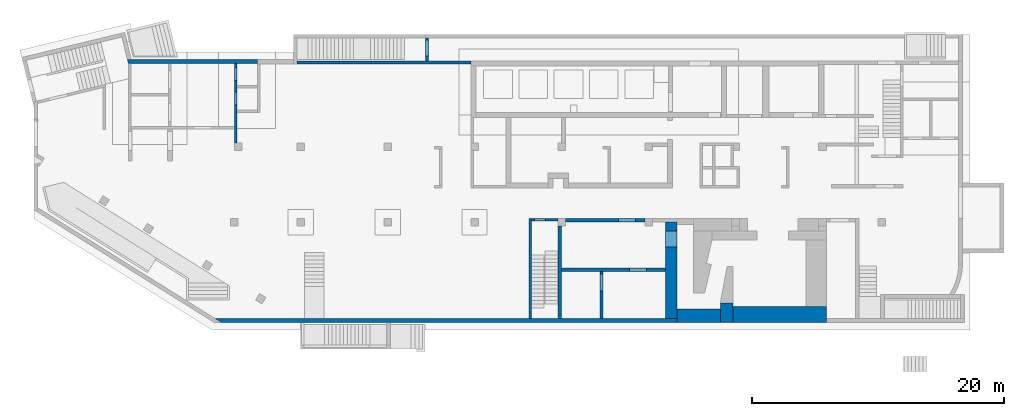
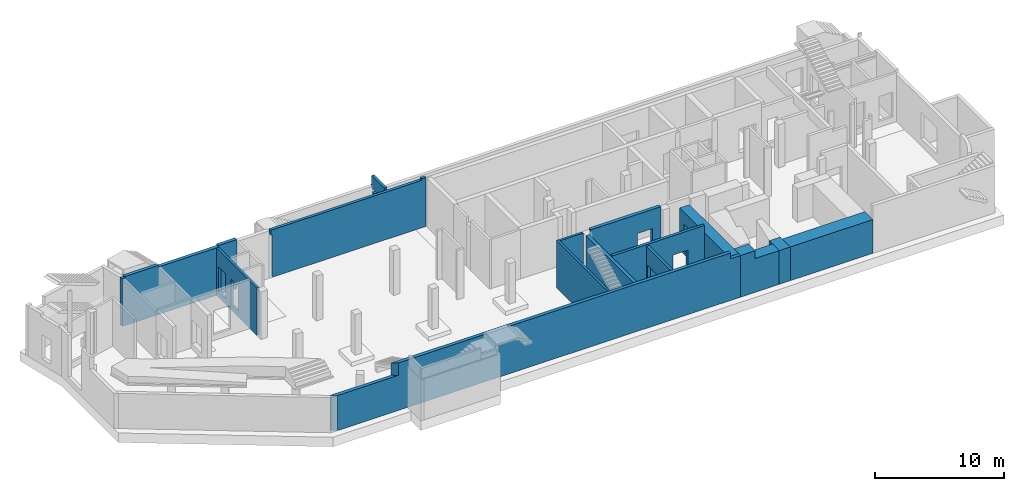
# One storey, part 6 of 9: 15 walls, 9 openings.
"""IFC4 building model written with IfcOpenShell, lengths in millimetres."""

from ifc_helpers import new_model, entity, si_unit, converted_unit, derived_unit, direction, frame, origin, place, context, subcontext, project, spatial, indexed_curve, outline, extrude, polygons, material, type_object, element, save


model = new_model("IFC4")

# Units and contexts
model_context = context("Model", 3, precision=0.01, world=origin(), true_north=direction((6.12303176911189e-17, 1.0)))
plan_context = context("Plan", 3, precision=0.01, world=origin(), true_north=direction((6.12303176911189e-17, 1.0)))
body_context = subcontext(model_context, "Body", "Model", "MODEL_VIEW")
ifc_project = project(units=[si_unit("LENGTHUNIT", "METRE", prefix="MILLI"), si_unit("AREAUNIT", "SQUARE_METRE"), si_unit("VOLUMEUNIT", "CUBIC_METRE"), converted_unit("PLANEANGLEUNIT", "DEGREE", entity("IfcRatioMeasure", 0.0174532925199433), si_unit("PLANEANGLEUNIT", "RADIAN"), dimensions=[0, 0, 0, 0, 0, 0, 0]), si_unit("MASSUNIT", "GRAM", prefix="KILO"), derived_unit("MASSDENSITYUNIT", [(si_unit("MASSUNIT", "GRAM", prefix="KILO"), 1), (si_unit("LENGTHUNIT", "METRE"), -3)]), derived_unit("MOMENTOFINERTIAUNIT", [(si_unit("LENGTHUNIT", "METRE"), 4)]), si_unit("TIMEUNIT", "SECOND"), si_unit("FREQUENCYUNIT", "HERTZ"), si_unit("THERMODYNAMICTEMPERATUREUNIT", "DEGREE_CELSIUS"), derived_unit("THERMALTRANSMITTANCEUNIT", [(si_unit("MASSUNIT", "GRAM", prefix="KILO"), 1), (si_unit("THERMODYNAMICTEMPERATUREUNIT", "KELVIN"), -1), (si_unit("TIMEUNIT", "SECOND"), -3)]), derived_unit("VOLUMETRICFLOWRATEUNIT", [(si_unit("LENGTHUNIT", "METRE"), 3), (si_unit("TIMEUNIT", "SECOND"), -1)]), derived_unit("MASSFLOWRATEUNIT", [(si_unit("MASSUNIT", "GRAM", prefix="KILO"), 1), (si_unit("TIMEUNIT", "SECOND"), -1)]), derived_unit("ROTATIONALFREQUENCYUNIT", [(si_unit("TIMEUNIT", "SECOND"), -1)]), si_unit("ELECTRICCURRENTUNIT", "AMPERE"), si_unit("ELECTRICVOLTAGEUNIT", "VOLT"), si_unit("POWERUNIT", "WATT"), si_unit("FORCEUNIT", "NEWTON", prefix="KILO"), si_unit("ILLUMINANCEUNIT", "LUX"), si_unit("LUMINOUSFLUXUNIT", "LUMEN"), si_unit("LUMINOUSINTENSITYUNIT", "CANDELA"), derived_unit("USERDEFINED", [(si_unit("MASSUNIT", "GRAM", prefix="KILO"), -1), (si_unit("LENGTHUNIT", "METRE"), -2), (si_unit("TIMEUNIT", "SECOND"), 3), (si_unit("LUMINOUSFLUXUNIT", "LUMEN"), 1)]), derived_unit("LINEARVELOCITYUNIT", [(si_unit("LENGTHUNIT", "METRE"), 1), (si_unit("TIMEUNIT", "SECOND"), -1)]), si_unit("PRESSUREUNIT", "PASCAL"), derived_unit("USERDEFINED", [(si_unit("LENGTHUNIT", "METRE"), -2), (si_unit("MASSUNIT", "GRAM", prefix="KILO"), 1), (si_unit("TIMEUNIT", "SECOND"), -2)]), derived_unit("LINEARFORCEUNIT", [(si_unit("MASSUNIT", "GRAM", prefix="KILO"), 1), (si_unit("LENGTHUNIT", "METRE"), 1), (si_unit("TIMEUNIT", "SECOND"), -2), (si_unit("LENGTHUNIT", "METRE"), -1)]), derived_unit("PLANARFORCEUNIT", [(si_unit("MASSUNIT", "GRAM", prefix="KILO"), 1), (si_unit("LENGTHUNIT", "METRE"), 1), (si_unit("TIMEUNIT", "SECOND"), -2), (si_unit("LENGTHUNIT", "METRE"), -2)])], contexts=[model_context, plan_context])

# Site, building, storey
site_placement = place(None, origin())
site = spatial("IfcSite", under=ifc_project, at=site_placement, CompositionType="ELEMENT")
building_placement = place(site_placement, origin())
building = spatial("IfcBuilding", under=site, at=building_placement, CompositionType="ELEMENT")
storey_placement = place(building_placement, frame((0.0, 0.0, -4900.0)))
storey = spatial("IfcBuildingStorey", under=building, at=storey_placement, CompositionType="ELEMENT", Elevation=-4900.0)

# Wall
ifc_material = material()
wall_type_1 = type_object("IfcWallType", Name=":ADSK_ 25_200", PredefinedType="STANDARD")
wall_1_placement = place(storey_placement, frame((39370.0, 50.0, 0.0), z_axis=(0.0, 0.0, 1.0), x_axis=(0.0, 1.0, 0.0)))
element("IfcWall", 1, at=wall_1_placement, inside=storey, type_object=wall_type_1, material=ifc_material, Name=":ADSK_ 25_200", ObjectType=":ADSK_ 25_200", PredefinedType="NOTDEFINED", context=body_context, shape_type="Tessellation", body=[
    polygons([(3.8915537459161e-13, -99.9999999999945, 0.0), (7749.99999999991, -99.9999999999934, 0.0), (7949.99999999991, -99.9999999999932, 0.0), (7949.99999999991, -99.9999999999932, 4500.0), (7749.99999999991, -99.9999999999934, 4500.0), (5325.0, -99.9999999999965, 4500.0), (1.26898491714655e-13, -99.9999999999945, 4500.0), (1.91193727516747e-12, 100.000000000003, 0.0), (1.51432200112822e-12, 100.000000000003, 4500.0), (7949.99999999991, 100.000000000005, 4500.0), (7949.99999999991, 100.000000000005, 0.0)], [[[1, 2, 3, 4, 5, 6, 7]], [[8, 9, 10, 11]], [[3, 2, 1, 8, 11]], [[1, 7, 9, 8]], [[4, 3, 11, 10]], [[7, 6, 5, 4, 10, 9]]], closed=True),
])

# Wall, opening
wall_2_placement = place(storey_placement, frame((41570.0, 7900.0, 0.0), z_axis=(0.0, 0.0, 1.0), x_axis=(-1.0, 0.0, 0.0)))
wall_2 = element("IfcWall", 2, at=wall_2_placement, inside=storey, type_object=wall_type_1, material=ifc_material, Name=":ADSK_ 25_200", ObjectType=":ADSK_ 25_200", PredefinedType="NOTDEFINED", context=body_context, shape_type="Tessellation", body=[
    polygons([(1.18902794510068e-12, -100.0, 0.0), (2100.00000000002, -100.000000000001, 0.0), (2100.00000000002, -100.000000000001, 4500.0), (1.18902794510068e-12, -100.0, 4500.0), (960.000000000008, -100.0, 2829.99999999805), (1840.00000000001, -100.000000000001, 2829.99999999804), (1840.00000000001, -100.000000000001, 550.0), (960.000000000008, -100.0, 550.0), (2100.00000000002, 99.9999999999978, 0.0), (5.09581903187964e-13, 100.0, 0.0), (5.09581903187964e-13, 100.0, 4500.0), (2100.00000000002, 99.9999999999978, 4500.0), (1840.00000000001, 99.9999999999989, 2829.99999999804), (960.000000000008, 100.000000000001, 2829.99999999805), (960.000000000008, 100.000000000001, 550.0), (1840.00000000001, 99.9999999999989, 550.0)], [[[1, 2, 3, 4], [5, 6, 7, 8]], [[9, 10, 11, 12], [13, 14, 15, 16]], [[2, 1, 10, 9]], [[4, 3, 12, 11]], [[1, 4, 11, 10]], [[3, 2, 9, 12]], [[5, 14, 13, 6]], [[6, 13, 16, 7]], [[7, 16, 15, 8]], [[14, 5, 8, 15]]], closed=True),
])
opening_1_placement = place(wall_2_placement, frame((41570.0, 7900.0, 0.0), z_axis=(0.0, 0.0, 1.0), x_axis=(-1.0, 0.0, 0.0)))
element("IfcOpeningElement", 3, at=opening_1_placement, cuts=wall_2, Name=":ADSK_ 25_200", PredefinedType="OPENING", context=body_context, shape_type="SweptSolid", body=[
    extrude(outline(indexed_curve([(-439.999999999995, -1139.99999999902), (440.000000000004, -1139.99999999902), (440.000000000004, 1139.99999999902), (-439.999999999995, 1139.99999999902), (-439.999999999995, -1139.99999999902)], self_intersect=False)), frame((40170.0, 8100.0, 1690.0), z_axis=(0.0, -1.0, 0.0), x_axis=(-1.0, 0.0, 0.0)), (0.0, 0.0, 1.0), 400.000000001942),
])

# Wall, openings
wall_3_placement = place(storey_placement, frame((16000.0, 14000.0, 0.0), z_axis=(0.0, 0.0, 1.0), x_axis=(0.0, 1.0, 0.0)))
wall_3 = element("IfcWall", 4, at=wall_3_placement, inside=storey, type_object=wall_type_1, material=ifc_material, Name=":ADSK_ 25_200", ObjectType=":ADSK_ 25_200", PredefinedType="NOTDEFINED", context=body_context, shape_type="Tessellation", body=[
    polygons([(0.0, -100.000000000001, 0.0), (2399.99999999961, -100.000000000001, 0.0), (2599.99999999961, -100.000000000001, 0.0), (4349.9999999998, -99.9999999999999, 0.0), (4549.9999999998, -100.000000000002, 0.0), (6300.0, -99.9999999999987, 0.0), (6300.0, -99.9999999999987, 4500.0), (2500.00063936648, -100.000000000001, 4500.0), (0.0, -100.000000000001, 4500.0), (2980.0, -100.0, 2919.99999999804), (4020.0, -100.0, 2919.99999999804), (4020.0, -100.0, 550.0), (2980.0, -100.0, 550.0), (4930.00000000001, -100.000000000001, 2919.99999999804), (5970.0, -99.9999999999992, 2919.99999999804), (5970.0, -99.9999999999992, 550.0), (4930.00000000001, -100.000000000001, 550.0), (6300.0, 99.9999999999992, 0.0), (1299.99999999955, 99.9999999999992, 0.0), (1099.99999999955, 99.9999999999989, 0.0), (0.0, 99.9999999999992, 0.0), (0.0, 99.9999999999992, 4500.0), (6300.0, 99.9999999999992, 4500.0), (4020.0, 99.9999999999996, 2919.99999999804), (2980.0, 99.9999999999978, 2919.99999999804), (2980.00000000001, 99.9999999999978, 550.0), (4020.0, 99.9999999999996, 550.0), (5970.0, 99.9999999999986, 2919.99999999804), (4930.00000000001, 99.999999999999, 2919.99999999804), (4930.00000000001, 99.999999999999, 550.0), (5970.0, 99.9999999999986, 550.0)], [[[1, 2, 3, 4, 5, 6, 7, 8, 9], [10, 11, 12, 13], [14, 15, 16, 17]], [[18, 19, 20, 21, 22, 23], [24, 25, 26, 27], [28, 29, 30, 31]], [[6, 5, 4, 3, 2, 1, 21, 20, 19, 18]], [[9, 8, 7, 23, 22]], [[1, 9, 22, 21]], [[7, 6, 18, 23]], [[24, 11, 10, 25]], [[25, 10, 13, 26]], [[26, 13, 12, 27]], [[11, 24, 27, 12]], [[28, 15, 14, 29]], [[29, 14, 17, 30]], [[30, 17, 16, 31]], [[15, 28, 31, 16]]], closed=True),
])
placement_1 = place(wall_3_placement, frame((-14000.0, 16000.0, 0.0), z_axis=(0.0, 0.0, 1.0), x_axis=(0.0, -1.0, 0.0)))
element("IfcOpeningElement", 5, at=placement_1, cuts=wall_3, Name=":ADSK_ 25_200", PredefinedType="OPENING", context=body_context, shape_type="SweptSolid", body=[
    extrude(outline(indexed_curve([(-1184.99999999902, -519.999999999999), (1184.99999999902, -519.999999999999), (1184.99999999902, 520.000000000001), (-1184.99999999902, 520.000000000001), (-1184.99999999902, -519.999999999999)], self_intersect=False)), frame((16200.0, 17500.0, 1735.0), z_axis=(-1.0, 0.0, 0.0), x_axis=(0.0, 0.0, -1.0)), (0.0, 0.0, 1.0), 400.000000001943),
])
element("IfcOpeningElement", 6, at=placement_1, cuts=wall_3, Name=":ADSK_ 25_200", PredefinedType="OPENING", context=body_context, shape_type="SweptSolid", body=[
    extrude(outline(indexed_curve([(-1184.99999999902, -519.999999999999), (1184.99999999902, -519.999999999999), (1184.99999999902, 519.999999999999), (-1184.99999999902, 519.999999999999), (-1184.99999999902, -519.999999999999)], self_intersect=False)), frame((16200.0, 19450.0, 1735.0), z_axis=(-1.0, 0.0, 0.0), x_axis=(0.0, 0.0, -1.0)), (0.0, 0.0, 1.0), 400.000000001943),
])

# Walls
wall_type_2 = type_object("IfcWallType", Name=":ADSK_ 25_300", PredefinedType="STANDARD")
wall_4_placement = place(storey_placement, frame((7420.41, 20450.0, 0.0)))
element("IfcWall", 7, at=wall_4_placement, inside=storey, type_object=wall_type_2, material=ifc_material, Name=":ADSK_ 25_300", ObjectType=":ADSK_ 25_300", PredefinedType="NOTDEFINED", context=body_context, shape_type="Tessellation", body=[
    polygons([(73.128173937497, -150.000000000005, 0.0), (79.587699244774, -150.000000000005, 0.0), (279.587699244774, -150.000000000005, 0.0), (3279.58769924477, -150.000000000005, 0.0), (3479.58769924477, -150.000000000001, 0.0), (8479.58769924478, -150.000000000001, 0.0), (8679.58769924478, -150.000000000001, 0.0), (10304.5876992448, -150.000000000005, 0.0), (10304.5876992448, -150.000000000005, 4500.0), (10304.5876992448, -150.000000000005, 4650.0), (8679.58769924479, -150.000000000001, 4650.0), (8679.58769924479, -150.000000000001, 4500.0), (8479.58769924478, -150.000000000001, 4500.0), (3479.58769924477, -150.000000000001, 4500.0), (3279.58769924479, -150.000000000005, 4500.0), (3279.58769924479, -150.000000000005, 4650.0), (279.587699244795, -150.000000000005, 4650.0), (279.587699244795, -150.000000000005, 4500.0), (79.587699244774, -150.000000000005, 4500.0), (73.1281739374959, -150.000000000005, 4500.0), (10304.5876992448, 149.999999999996, 0.0), (308.784277163578, 149.999999999996, 0.0), (2.77954970644349e-12, 150.000000000001, 0.0), (6.13815447846702e-13, 150.000000000001, 1670.0), (6.13815447846702e-13, 150.000000000001, 1870.0), (-4.69051681451691e-13, 150.000000000001, 4500.0), (279.587699244792, 149.999999999996, 4500.0), (279.587699244792, 149.999999999996, 4650.0), (3279.58769924479, 149.999999999996, 4650.0), (3279.58769924479, 149.999999999992, 4500.0), (8679.58769924478, 150.000000000001, 4500.0), (8679.58769924478, 150.000000000001, 4650.0), (10304.5876992448, 149.999999999996, 4650.0), (10304.5876992448, 149.999999999996, 4500.0), (10304.5876992448, 50.0006393664798, 4650.0)], [[[1, 2, 3, 4, 5, 6, 7, 8, 9, 10, 11, 12, 13, 14, 15, 16, 17, 18, 19, 20]], [[21, 22, 23, 24, 25, 26, 27, 28, 29, 30, 31, 32, 33, 34]], [[8, 7, 6, 5, 4, 3, 2, 1, 23, 22, 21]], [[11, 10, 35, 33, 32]], [[23, 1, 20, 26, 25, 24]], [[8, 21, 34, 33, 35, 10, 9]], [[12, 31, 30, 15, 14, 13]], [[27, 18, 17, 28]], [[15, 30, 29, 16]], [[31, 12, 11, 32]], [[18, 27, 26, 20, 19]], [[17, 16, 29, 28]]], closed=True),
])
wall_5_placement = place(storey_placement, frame((14391.94, -100.0, 0.0)))
element("IfcWall", 8, at=wall_5_placement, inside=storey, type_object=wall_type_2, material=ifc_material, Name=":ADSK_ 25_300", ObjectType=":ADSK_ 25_300", PredefinedType="NOTDEFINED", context=body_context, shape_type="Tessellation", body=[
    polygons([(480.109728548428, -150.0, 0.0), (6748.06078403981, -150.0, 0.0), (7048.06078403981, -150.0, 0.0), (13598.0607840398, -150.0, 0.0), (13898.0607840398, -150.0, 0.0), (36628.0607840398, -150.0, 0.0), (36628.0607840398, -150.000000000014, 3950.0), (35728.0607840398, -150.0, 3950.0), (35728.0607840398, -150.0, 4500.0), (27178.0607840398, -150.0, 4500.0), (25078.0607840398, -150.000000000001, 4500.0), (5952.71829370465, -150.000000000001, 4500.0), (5952.71829370465, -150.000000000002, 3580.0), (5952.71829370465, -150.000000000001, 3330.0), (480.109728548424, -150.0, 3330.0), (-2.51150603102073e-12, 150.0, 0.0), (6.15143100336641e-12, 150.000000000001, 3330.0), (5472.60856515624, 149.999999999999, 3330.0), (5472.60856515624, 149.999999999999, 4500.0), (6793.58304640091, 150.0, 4500.0), (24878.0607840398, 150.0, 4500.0), (25078.0607840398, 150.0, 4500.0), (27178.0607840398, 150.0, 4500.0), (27478.0607840398, 150.0, 4500.0), (30508.0607840398, 150.0, 4500.0), (30758.0607840398, 150.0, 4500.0), (35728.0607840398, 150.0, 4500.0), (35728.0607840398, 150.0, 3950.0), (36628.0607840398, 150.0, 3950.0), (36628.0607840398, 150.0, 0.0), (35728.0607840398, 150.0, 0.0), (30758.0607840398, 150.0, 0.0), (30508.0607840398, 150.0, 0.0), (27478.0607840398, 150.0, 0.0), (27178.0607840398, 150.0, 0.0), (25078.0607840398, 150.0, 0.0), (24878.0607840398, 150.0, 0.0)], [[[1, 2, 3, 4, 5, 6, 7, 8, 9, 10, 11, 12, 13, 14, 15]], [[16, 17, 18, 19, 20, 21, 22, 23, 24, 25, 26, 27, 28, 29, 30, 31, 32, 33, 34, 35, 36, 37]], [[6, 5, 4, 3, 2, 1, 16, 37, 36, 35, 34, 33, 32, 31, 30]], [[1, 15, 17, 16]], [[7, 6, 30, 29]], [[11, 10, 23, 22]], [[12, 19, 18, 14, 13]], [[27, 9, 8, 28]], [[10, 9, 27, 26, 25, 24, 23]], [[12, 11, 22, 21, 20, 19]], [[15, 14, 18, 17]], [[8, 7, 29, 28]]], closed=True),
])
wall_6_placement = place(storey_placement, frame((41720.0, 50.0, 0.0), z_axis=(0.0, 0.0, 1.0), x_axis=(0.0, 1.0, 0.0)))
element("IfcWall", 9, at=wall_6_placement, inside=storey, type_object=wall_type_2, material=ifc_material, Name=":ADSK_ 25_300", ObjectType=":ADSK_ 25_300", PredefinedType="NOTDEFINED", context=body_context, shape_type="Tessellation", body=[
    polygons([(3.38395977905748e-14, -150.000000000001, 0.0), (3749.99999999999, -150.000000000005, 0.0), (3999.99999999999, -150.000000000004, 0.0), (7349.99999999992, -150.000000000001, 0.0), (7349.99999999992, -150.000000000001, 4500.0), (8.45989944764369e-15, -150.000000000001, 4500.0), (1.81887838124339e-12, 150.000000000001, 0.0), (1.75965908510989e-12, 150.000000000001, 4500.0), (5325.00000000001, 149.999999999998, 4500.0), (7349.99999999992, 150.000000000001, 4500.0), (7349.99999999992, 150.000000000001, 0.0)], [[[1, 2, 3, 4, 5, 6]], [[7, 8, 9, 10, 11]], [[4, 3, 2, 1, 7, 11]], [[5, 4, 11, 10]], [[1, 6, 8, 7]], [[6, 5, 10, 9, 8]]], closed=True),
])

# Wall, opening
wall_7_placement = place(storey_placement, frame((42170.0, 7850.0, 0.0)))
wall_7 = element("IfcWall", 10, at=wall_7_placement, inside=storey, type_object=wall_type_2, material=ifc_material, Name=":ADSK_ 25_300", ObjectType=":ADSK_ 25_300", PredefinedType="NOTDEFINED", context=body_context, shape_type="Tessellation", body=[
    polygons([(8.42232516012628e-13, -149.999999999999, 0.0), (6299.99999999999, -149.999999999999, 0.0), (6299.99999999999, -149.999999999999, 4650.0), (8.42232516012628e-13, -149.999999999999, 4650.0), (4199.99999999998, -149.999999999998, 2829.99999999805), (5549.99999999999, -149.999999999998, 2829.99999999804), (5549.99999999999, -149.999999999998, 550.0), (4199.99999999998, -149.999999999998, 550.0), (6299.99999999999, 150.000000000001, 0.0), (-1.37504410495438e-13, 149.999999999999, 0.0), (-1.37504410495442e-13, 150.000000000001, 4500.0), (-1.37504410495438e-13, 149.999999999999, 4650.0), (6299.99999999999, 150.000000000001, 4650.0), (6299.99999999999, 150.000000000001, 4500.0), (5549.99999999999, 150.000000000001, 2829.99999999804), (4199.99999999998, 150.000000000001, 2829.99999999805), (4199.99999999998, 150.000000000001, 550.0), (5549.99999999999, 150.000000000001, 550.0)], [[[1, 2, 3, 4], [5, 6, 7, 8]], [[9, 10, 11, 12, 13, 14], [15, 16, 17, 18]], [[2, 1, 10, 9]], [[3, 2, 9, 14, 13]], [[4, 3, 13, 12]], [[1, 4, 12, 11, 10]], [[5, 16, 15, 6]], [[6, 15, 18, 7]], [[7, 18, 17, 8]], [[16, 5, 8, 17]]], closed=True),
])
opening_4_placement = place(wall_7_placement, frame((-42170.0, -7850.0, 0.0)))
element("IfcOpeningElement", 11, at=opening_4_placement, cuts=wall_7, Name=":ADSK_ 25_300", PredefinedType="OPENING", context=body_context, shape_type="SweptSolid", body=[
    extrude(outline(indexed_curve([(-675.000000000003, -1139.99999999902), (674.999999999994, -1139.99999999902), (674.999999999994, 1139.99999999902), (-675.000000000003, 1139.99999999902), (-675.000000000003, -1139.99999999902)], self_intersect=False)), frame((47045.0, 7600.0, 1690.0), z_axis=(0.0, 1.0, 0.0), x_axis=(1.0, 0.0, 0.0)), (0.0, 0.0, 1.0), 500.000000001943),
])

wall_type_3 = type_object("IfcWallType", Name=":ADSK_ 25_250", PredefinedType="STANDARD")
wall_8_placement = place(storey_placement, frame((41870.0, 3925.0, 0.0)))
wall_8 = element("IfcWall", 12, at=wall_8_placement, inside=storey, type_object=wall_type_3, material=ifc_material, Name=":ADSK_ 25_250", ObjectType=":ADSK_ 25_250", PredefinedType="NOTDEFINED", context=body_context, shape_type="Tessellation", body=[
    polygons([(-3.3681141022685e-12, -125.0, 0.0), (3029.99999999998, -125.0, 0.0), (3279.99999999999, -125.0, 0.0), (8249.99999999999, -125.0, 0.0), (8249.99999999999, -125.0, 4650.0), (-3.3681141022685e-12, -125.0, 4650.0), (5399.99999999998, -125.000000000001, 2829.99999999804), (6749.99999999999, -125.000000000001, 2829.99999999805), (6749.99999999999, -125.000000000001, 550.0), (5399.99999999998, -125.000000000001, 550.0), (8249.99999999999, 124.999999999999, 0.0), (-4.15963078556216e-12, 124.999999999999, 0.0), (-4.15963078556216e-12, 124.999999999999, 4650.0), (8249.99999999999, 124.999999999999, 4650.0), (6749.99999999999, 125.0, 2829.99999999805), (5399.99999999998, 125.0, 2829.99999999804), (5399.99999999998, 125.0, 550.0), (6749.99999999999, 125.0, 550.0)], [[[1, 2, 3, 4, 5, 6], [7, 8, 9, 10]], [[11, 12, 13, 14], [15, 16, 17, 18]], [[4, 3, 2, 1, 12, 11]], [[6, 5, 14, 13]], [[1, 6, 13, 12]], [[5, 4, 11, 14]], [[15, 8, 7, 16]], [[16, 7, 10, 17]], [[17, 10, 9, 18]], [[8, 15, 18, 9]]], closed=True),
])
opening_5_placement = place(wall_8_placement, frame((-41870.0, -3925.0, 0.0)))
element("IfcOpeningElement", 13, at=opening_5_placement, cuts=wall_8, Name=":ADSK_ 25_250", PredefinedType="OPENING", context=body_context, shape_type="SweptSolid", body=[
    extrude(outline(indexed_curve([(-1139.99999999902, -674.999999999994), (1139.99999999902, -674.999999999994), (1139.99999999902, 675.000000000003), (-1139.99999999902, 675.000000000003), (-1139.99999999902, -674.999999999994)], self_intersect=False)), frame((47945.0, 3700.0, 1690.0), z_axis=(0.0, 1.0, 0.0), x_axis=(0.0, 0.0, -1.0)), (0.0, 0.0, 1.0), 450.000000000965),
])

wall_9_placement = place(storey_placement, frame((45025.0, 3800.0, 0.0), z_axis=(0.0, 0.0, 1.0), x_axis=(0.0, -1.0, 0.0)))
wall_9 = element("IfcWall", 14, at=wall_9_placement, inside=storey, type_object=wall_type_3, material=ifc_material, Name=":ADSK_ 25_250", ObjectType=":ADSK_ 25_250", PredefinedType="NOTDEFINED", context=body_context, shape_type="Tessellation", body=[
    polygons([(0.0, -125.000000000007, 0.0), (3750.00000000001, -125.000000000006, 0.0), (3750.00000000001, -125.000000000006, 4500.0), (0.0, -125.000000000007, 4500.0), (200.0, -125.000000000007, 2829.99999999804), (1550.0, -125.000000000003, 2829.99999999805), (1550.0, -125.000000000003, 550.0), (200.000000000001, -125.000000000007, 550.0), (3750.00000000001, 124.999999999997, 0.0), (-5.41433564649196e-13, 124.999999999996, 0.0), (-5.41433564649196e-13, 124.999999999996, 4500.0), (3750.00000000001, 124.999999999997, 4500.0), (1550.0, 125.0, 2829.99999999805), (200.000000000001, 124.999999999997, 2829.99999999804), (200.000000000001, 124.999999999997, 550.0), (1550.0, 125.0, 550.0)], [[[1, 2, 3, 4], [5, 6, 7, 8]], [[9, 10, 11, 12], [13, 14, 15, 16]], [[2, 1, 10, 9]], [[3, 2, 9, 12]], [[1, 4, 11, 10]], [[4, 3, 12, 11]], [[13, 6, 5, 14]], [[14, 5, 8, 15]], [[15, 8, 7, 16]], [[6, 13, 16, 7]]], closed=True),
])
opening_6_placement = place(wall_9_placement, frame((3800.0, -45025.0, 0.0), z_axis=(0.0, 0.0, 1.0), x_axis=(0.0, 1.0, 0.0)))
element("IfcOpeningElement", 15, at=opening_6_placement, cuts=wall_9, Name=":ADSK_ 25_250", PredefinedType="OPENING", context=body_context, shape_type="SweptSolid", body=[
    extrude(outline(indexed_curve([(-1139.99999999902, -675.0), (1139.99999999902, -675.0), (1139.99999999902, 675.0), (-1139.99999999902, 675.0), (-1139.99999999902, -675.0)], self_intersect=False)), frame((44800.0, 2925.0, 1690.0), z_axis=(1.0, 0.0, 0.0), x_axis=(0.0, 0.0, -1.0)), (0.0, 0.0, 1.0), 450.000000000963),
])

# Wall
wall_10_placement = place(storey_placement, frame((34670.0, 20375.0, 0.0), z_axis=(0.0, 0.0, 1.0), x_axis=(-1.0, 0.0, 0.0)))
element("IfcWall", 16, at=wall_10_placement, inside=storey, type_object=wall_type_3, material=ifc_material, Name=":ADSK_ 25_250", ObjectType=":ADSK_ 25_250", PredefinedType="NOTDEFINED", context=body_context, shape_type="Tessellation", body=[
    polygons([(-5.34363569620451e-13, -124.999999999998, 0.0), (3360.0, -124.999999999998, 0.0), (3610.0, -125.000000000002, 0.0), (13780.0, -124.999999999998, 0.0), (13780.0, -124.999999999998, 4035.0), (13930.0, -124.999999999998, 4035.0), (13930.0, -124.999999999998, 4500.0), (399.999999999952, -125.000213122213, 4500.0), (399.999999999952, -124.999999999998, 4650.0), (-5.34363569620451e-13, -124.999999999998, 4650.0), (-5.34363569620451e-13, -124.999999999998, 4450.0), (13780.0, 125.000000000002, 0.0), (-1.32018877230434e-12, 125.000000000002, 0.0), (-1.32018877230434e-12, 125.000000000002, 4650.0), (399.999999999951, 125.000000000002, 4650.0), (399.999999999951, 125.000000000002, 4500.0), (13930.0, 125.000000000002, 4500.0), (13930.0, 125.000000000002, 4035.0), (13780.0, 125.000000000002, 4035.0)], [[[1, 2, 3, 4, 5, 6, 7, 8, 9, 10, 11]], [[12, 13, 14, 15, 16, 17, 18, 19]], [[4, 3, 2, 1, 13, 12]], [[14, 10, 9, 15]], [[1, 11, 10, 14, 13]], [[6, 18, 17, 7]], [[18, 6, 5, 19]], [[4, 12, 19, 5]], [[16, 8, 7, 17]], [[8, 16, 15, 9]]], closed=True),
])

# Wall, openings
placement_2 = place(storey_placement, frame((31185.0, 20500.0, 0.0), z_axis=(0.0, 0.0, 1.0), x_axis=(0.0, 1.0, 0.0)))
wall_11 = element("IfcWall", 17, at=placement_2, inside=storey, type_object=wall_type_3, material=ifc_material, Name=":ADSK_ 25_250", ObjectType=":ADSK_ 25_250", PredefinedType="NOTDEFINED", context=body_context, shape_type="Tessellation", body=[
    polygons([(0.0, -124.999999999996, 0.0), (1799.99999999994, -124.999999999992, 0.0), (1799.99999999994, -124.999999999992, 3300.0), (0.0, -124.999999999996, 3300.0), (399.999999999939, -124.999999999995, 2829.99999999805), (1649.99999999994, -124.999999999992, 2829.99999999804), (1649.99999999994, -124.999999999992, 550.0), (399.999999999939, -124.999999999995, 550.0), (1799.99999999994, 125.000000000004, 0.0), (4.33146851719357e-12, 125.000000000004, 0.0), (4.33146851719357e-12, 125.000000000004, 3300.0), (1799.99999999994, 125.000000000008, 3300.0), (1649.99999999994, 125.000000000003, 2829.99999999804), (399.999999999939, 125.000000000005, 2829.99999999805), (399.999999999939, 125.000000000005, 550.0), (1649.99999999994, 125.000000000003, 550.0)], [[[1, 2, 3, 4], [5, 6, 7, 8]], [[9, 10, 11, 12], [13, 14, 15, 16]], [[2, 1, 10, 9]], [[10, 1, 4, 11]], [[2, 9, 12, 3]], [[4, 3, 12, 11]], [[5, 14, 13, 6]], [[16, 7, 6, 13]], [[7, 16, 15, 8]], [[8, 15, 14, 5]]], closed=True),
    polygons([(0.0, -124.999999999996, 4725.0), (1999.99999999993, -124.999999999991, 4725.0), (1999.99999999993, 125.000000000004, 4725.0), (1799.99999999993, 125.000000000004, 4725.0), (4.33146851719357e-12, 125.000000000004, 4725.0), (2099.99999999994, -125.0, 3550.0), (0.0, -124.999999999996, 3550.0), (4.33146851719357e-12, 125.000000000004, 3550.0), (2099.99999999994, 125.000000000009, 3550.0), (1999.99999999993, -124.999999999991, 3825.0), (2099.99999999994, -125.0, 3825.0), (2099.99999999994, 125.000000000004, 3825.0), (1999.99999999993, 125.000000000004, 3825.0)], [[[1, 2, 3, 4, 5]], [[6, 7, 8, 9]], [[10, 11, 12, 13]], [[12, 11, 6, 9]], [[3, 2, 10, 13]], [[1, 5, 8, 7]], [[5, 4, 3, 13, 12, 9, 8]], [[2, 1, 7, 6, 11, 10]]], closed=True),
])
element("IfcOpeningElement", 18, at=placement_2, cuts=wall_11, Name=":ADSK_ 25_250:1", PredefinedType="OPENING", context=body_context, shape_type="SweptSolid", body=[
    extrude(outline(indexed_curve([(-899.999999999968, -125.0), (899.999999999969, -125.0), (899.999999999968, 125.000000000004), (-899.999999999965, 125.0), (-899.999999999968, -125.0)], self_intersect=False)), frame((900.0, 0.0, 3300.0)), (0.0, 0.0, 1.0), 250.0),
])
opening_8_placement = place(placement_2, frame((-20500.0, 31185.0, 0.0), z_axis=(0.0, 0.0, 1.0), x_axis=(0.0, -1.0, 0.0)))
element("IfcOpeningElement", 19, at=opening_8_placement, cuts=wall_11, Name=":ADSK_ 25_250", PredefinedType="OPENING", context=body_context, shape_type="SweptSolid", body=[
    extrude(outline(indexed_curve([(-625.000000000001, -1139.99999999902), (625.000000000001, -1139.99999999902), (625.000000000001, 1139.99999999902), (-625.000000000001, 1139.99999999902), (-625.000000000001, -1139.99999999902)], self_intersect=False)), frame((31410.0, 21525.0, 1690.0), z_axis=(-1.0, 0.0, 0.0), x_axis=(0.0, 1.0, 0.0)), (0.0, 0.0, 1.0), 450.000000000968),
])

# Wall, opening
wall_type_4 = type_object("IfcWallType", Name=":ADSK_ 25_900", PredefinedType="STANDARD")
wall_12_placement = place(storey_placement, frame((50570.0, 50.0, 0.0), z_axis=(0.0, 0.0, 1.0), x_axis=(0.0, 1.0, 0.0)))
wall_12 = element("IfcWall", 20, at=wall_12_placement, inside=storey, type_object=wall_type_4, material=ifc_material, Name=":ADSK_ 25_900", ObjectType=":ADSK_ 25_900", PredefinedType="NOTDEFINED", context=body_context, shape_type="Tessellation", body=[
    polygons([(0.0, -450.000000000002, 0.0), (750.0, -450.0, 0.0), (7449.99999999995, -449.999999999999, 0.0), (7649.99999999996, -449.999999999998, 0.0), (7649.99999999996, -449.999999999998, 3950.0), (7449.99999999996, -449.999999999999, 3950.0), (750.0, -450.0, 3950.0), (2.96096480667529e-13, -450.000000000002, 3950.0), (5699.99999999996, -450.000000000001, 2829.99999999805), (6949.99999999996, -449.999999999999, 2829.99999999804), (6949.99999999996, -449.999999999999, 550.0), (5699.99999999996, -450.000000000001, 550.0), (7649.99999999996, 450.000000000005, 0.0), (4000.00000000003, 449.999999999999, 0.0), (3750.00000000003, 449.999999999999, 0.0), (4.46682690835587e-12, 450.000000000002, 0.0), (4.83906248405219e-12, 450.000000000002, 3950.0), (7649.99999999996, 450.000000000005, 3950.0), (6949.99999999996, 450.000000000004, 2829.99999999804), (5699.99999999996, 450.000000000002, 2829.99999999805), (5699.99999999996, 450.000000000002, 550.0), (6949.99999999996, 450.000000000004, 550.0), (7649.99999999996, 3.26519321837455e-12, 3950.0)], [[[1, 2, 3, 4, 5, 6, 7, 8], [9, 10, 11, 12]], [[13, 14, 15, 16, 17, 18], [19, 20, 21, 22]], [[4, 3, 2, 1, 16, 15, 14, 13]], [[5, 4, 13, 18, 23]], [[1, 8, 17, 16]], [[8, 7, 6, 5, 23, 18, 17]], [[9, 20, 19, 10]], [[10, 19, 22, 11]], [[11, 22, 21, 12]], [[20, 9, 12, 21]]], closed=True),
])
opening_9_placement = place(wall_12_placement, frame((-50.0, 50570.0, 0.0), z_axis=(0.0, 0.0, 1.0), x_axis=(0.0, -1.0, 0.0)))
element("IfcOpeningElement", 21, at=opening_9_placement, cuts=wall_12, Name=":ADSK_ 25_900", PredefinedType="OPENING", context=body_context, shape_type="SweptSolid", body=[
    extrude(outline(indexed_curve([(-625.0, -1139.99999999902), (625.0, -1139.99999999902), (625.0, 1139.99999999902), (-625.0, 1139.99999999902), (-625.0, -1139.99999999902)], self_intersect=False)), frame((51120.0, 6375.0, 1690.0), z_axis=(-1.0, 0.0, 0.0), x_axis=(0.0, 1.0, 0.0)), (0.0, 0.0, 1.0), 1100.00000000194),
])

# Walls
wall_type_5 = type_object("IfcWallType", Name=":ADSK_ 25_1050", PredefinedType="STANDARD")
wall_13_placement = place(storey_placement, frame((51020.0, 275.0, 0.0)))
element("IfcWall", 22, at=wall_13_placement, inside=storey, type_object=wall_type_5, material=ifc_material, Name=":ADSK_ 25_1050", ObjectType=":ADSK_ 25_1050", PredefinedType="NOTDEFINED", context=body_context, shape_type="Tessellation", body=[
    polygons([(1.70390577124004e-12, -525.0, 0.0), (3450.0, -525.0, 0.0), (3450.0, -525.000000000011, 3200.0), (1300.0, -525.0, 3200.0), (1300.0, -525.0, 3950.0), (1.70390577124004e-12, -525.0, 3950.0), (-5.45247632200275e-12, 525.0, 0.0), (-5.45247632200275e-12, 525.0, 3950.0), (1299.99999999999, 525.0, 3950.0), (1299.99999999999, 525.0, 3200.0), (3449.99999999999, 525.0, 3200.0), (3449.99999999999, 525.0, 0.0), (-3.40774826829325e-13, -225.0, 0.0), (-3.40774826829325e-13, -225.0, 3950.0)], [[[1, 2, 3, 4, 5, 6]], [[7, 8, 9, 10, 11, 12]], [[2, 1, 13, 7, 12]], [[1, 6, 14, 8, 7, 13]], [[3, 2, 12, 11]], [[6, 5, 9, 8, 14]], [[9, 5, 4, 10]], [[4, 3, 11, 10]]], closed=True),
])
wall_type_6 = type_object("IfcWallType", Name=":ADSK_ 25_1250", PredefinedType="STANDARD")
wall_14_placement = place(storey_placement, frame((55470.0, 375.0, 0.0)))
element("IfcWall", 23, at=wall_14_placement, inside=storey, type_object=wall_type_6, material=ifc_material, Name=":ADSK_ 25_1250", ObjectType=":ADSK_ 25_1250", PredefinedType="NOTDEFINED", context=body_context, shape_type="Tessellation", body=[
    polygons([(1.03859299249257e-11, -625.0, 0.0), (7400.00000000002, -625.0, 0.0), (7400.00000000002, -625.0, 3200.0), (1.03859299249257e-11, -625.0, 3200.0), (1.77099213181024e-12, 625.0, 0.0), (1.77099213181024e-12, 625.0, 3200.0), (5800.00000000001, 625.0, 3200.0), (7400.00000000002, 625.0, 3200.0), (7400.00000000001, 625.0, 0.0), (5800.00000000001, 625.0, 0.0), (7400.00000000002, -325.0, 0.0)], [[[1, 2, 3, 4]], [[5, 6, 7, 8, 9, 10]], [[2, 1, 5, 10, 9, 11]], [[1, 4, 6, 5]], [[3, 2, 11, 9, 8]], [[4, 3, 8, 7, 6]]], closed=True),
])
wall_type_7 = type_object("IfcWallType", Name=":ADSK_ 25_1000", PredefinedType="STANDARD")
wall_15_placement = place(storey_placement, frame((54970.0, -250.0, 0.0), z_axis=(0.0, 0.0, 1.0), x_axis=(0.0, 1.0, 0.0)))
element("IfcWall", 24, at=wall_15_placement, inside=storey, type_object=wall_type_7, material=ifc_material, Name=":ADSK_ 25_1000", ObjectType=":ADSK_ 25_1000", PredefinedType="NOTDEFINED", context=body_context, shape_type="Tessellation", body=[
    polygons([(2.97788460557058e-11, -499.999999999999, 0.0), (1250.00000000003, -499.999999999999, 0.0), (1550.00000000004, -499.999999999999, 0.0), (1550.00000000004, -499.999999999999, 3200.0), (1250.00000000003, -499.999999999999, 3200.0), (9.91500215263841e-12, -499.999999999999, 3200.0), (3.66821240049831e-11, 499.999999999999, 0.0), (3.65806052116113e-11, 499.999999999999, 3200.0), (1050.00000000004, 499.999999999999, 3200.0), (1550.00000000004, 499.999999999999, 3200.0), (1550.00000000004, 499.999999999999, 0.0), (1050.00000000004, 499.999999999999, 0.0)], [[[1, 2, 3, 4, 5, 6]], [[7, 8, 9, 10, 11, 12]], [[3, 2, 1, 7, 12, 11]], [[4, 3, 11, 10]], [[1, 6, 8, 7]], [[6, 5, 4, 10, 9, 8]]], closed=True),
])

save(model, "model.ifc")
